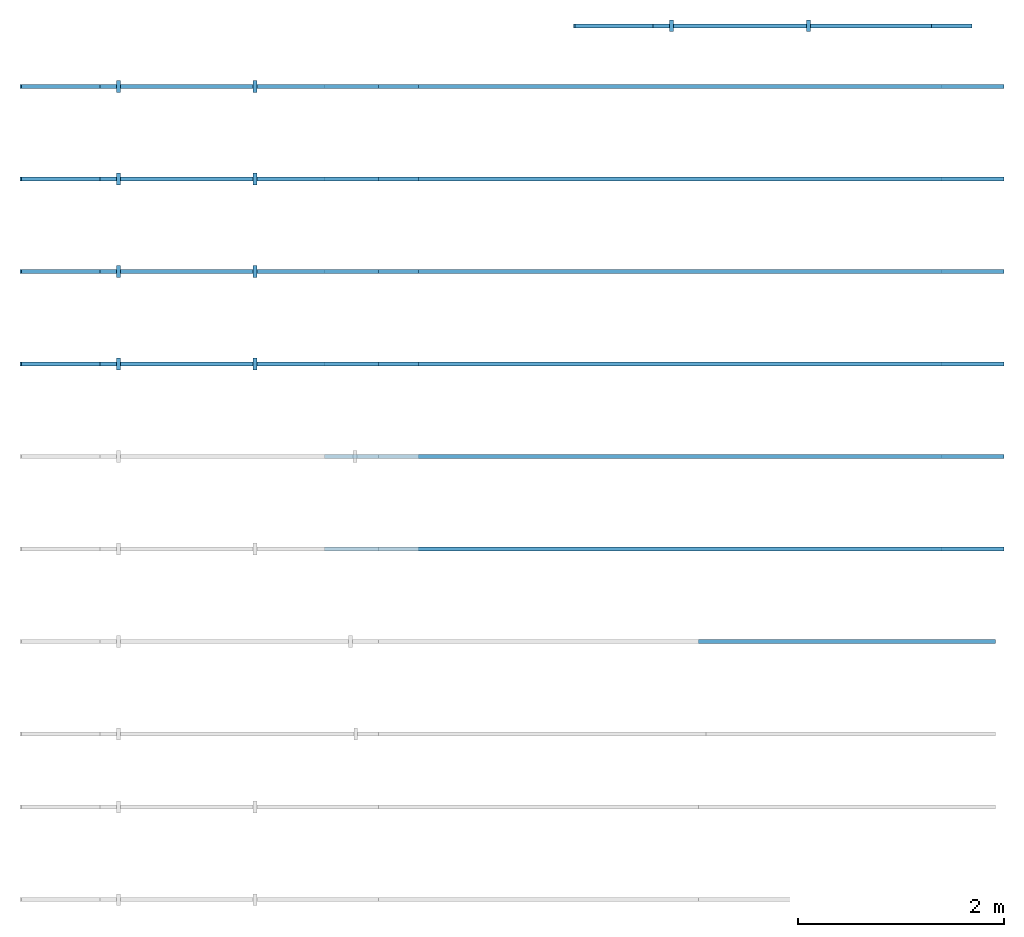
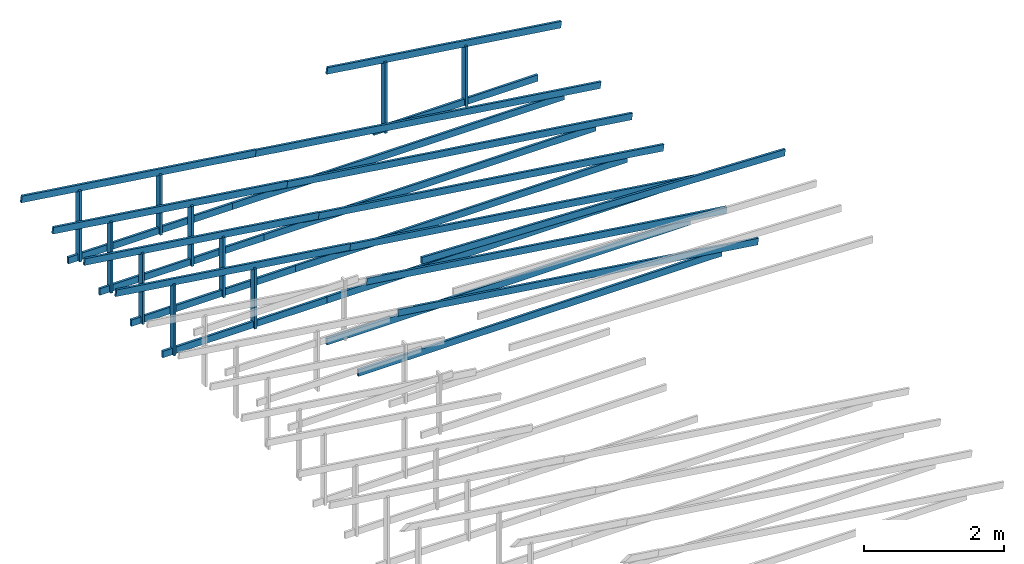
# Not in any storey, part 2 of 2: 33 roofs, 1 element without a shape of its own.
"""IFC4 model written with IfcOpenShell, lengths in millimetres."""

from ifc_helpers import new_model, entity, si_unit, converted_unit, frame, origin_with_axes, origin_2d_with_axis, place, context, subcontext, project, rectangle, extrude, material, material_profile, profile_set, profile_usage, type_object, element, aggregate, save


model = new_model("IFC4")

# Units and contexts
model_context = context("Model", 3, precision=1e-05, world=origin_with_axes())
plan_context = context("Plan", 2, precision=1e-05, world=origin_2d_with_axis())
body_context = subcontext(model_context, "Body", "Model", "MODEL_VIEW")
ifc_project = project(units=[si_unit("VOLUMEUNIT", "CUBIC_METRE"), si_unit("LENGTHUNIT", "METRE", prefix="MILLI"), converted_unit("PLANEANGLEUNIT", "degree", entity("IfcReal", 0.0174532925199433), si_unit("PLANEANGLEUNIT", "RADIAN"), dimensions=[0, 0, 0, 0, 0, 0, 0]), si_unit("AREAUNIT", "SQUARE_METRE")], contexts=[model_context, plan_context])

# Assembly, roofs
assembly_placement = place(None, frame((8638.14163208008, 12731.990814209, 0.0), z_axis=(0.0, 0.0, 1.0), x_axis=(-0.999999999999947, -3.25841369885876e-07, 0.0)))
assembly = element("IfcElementAssembly", 1, at=assembly_placement, Name="Assembly")
ifc_material = material()
ifc_material_profile = material_profile(ifc_material, rectangle(XDim=38.0, YDim=114.0))
ifc_profile_set = profile_set([ifc_material_profile])
ifc_profile_usage_1 = profile_usage(ifc_profile_set, cardinal=5)
roof_type = type_object("IfcRoofType", Name="timber 38x114", PredefinedType="BARREL_ROOF", material=ifc_profile_set)
roof_1_placement = place(assembly_placement, frame((239.999914488218, 439.999502181424, 2478.00016403198), z_axis=(0.99999999999995, -3.13916489247373e-07, -4.37113882867379e-08), x_axis=(3.13916489247373e-07, 0.999999999999951, 0.0)))
roof_1 = element("IfcRoof", 2, at=roof_1_placement, type_object=roof_type, material=ifc_profile_usage_1, Name="Beam", PredefinedType="BARREL_ROOF", context=body_context, shape_type="SweptSolid", body=[
    extrude(rectangle(XDim=38.0, YDim=114.0), origin_with_axes(), (0.0, 0.0, 1.0), 6000.00000000001),
])
ifc_profile_usage_2 = profile_usage(ifc_profile_set, cardinal=5)
roof_2_placement = place(assembly_placement, frame((-359.99951330716, 439.999697686058, 2465.76333045959), z_axis=(0.990268068702914, 1.5806549725193e-07, 0.139173101235031), x_axis=(-1.62920684942918e-07, 0.999999999999986, 2.34930119802329e-08)))
roof_2 = element("IfcRoof", 3, at=roof_2_placement, type_object=roof_type, material=ifc_profile_usage_2, Name="Beam.044", PredefinedType="BARREL_ROOF", context=body_context, shape_type="SweptSolid", body=[
    extrude(rectangle(XDim=38.0, YDim=114.0), origin_with_axes(), (0.0, 0.0, 1.0), 6000.00000000001),
])
ifc_profile_usage_3 = profile_usage(ifc_profile_set, cardinal=5)
roof_3_placement = place(assembly_placement, frame((5334.54051049656, 439.998795843653, 3273.04244041443), z_axis=(0.990268086286663, 1.71346197440185e-07, 0.139172976120085), x_axis=(-1.62920684942918e-07, 0.999999999999984, -7.19328738796233e-08)))
roof_3 = element("IfcRoof", 4, at=roof_3_placement, type_object=roof_type, material=ifc_profile_usage_3, Name="Beam.027", PredefinedType="BARREL_ROOF", context=body_context, shape_type="SweptSolid", body=[
    extrude(rectangle(XDim=38.0, YDim=114.0), origin_with_axes(), (0.0, 0.0, 1.0), 3899.99944705231),
])
ifc_profile_usage_4 = profile_usage(ifc_profile_set, cardinal=5)
roof_4_placement = place(assembly_placement, frame((5719.12875207369, 439.998670528894, 2478.00016403198), z_axis=(0.999999999999973, 1.62920684942916e-07, -1.62920684942925e-07), x_axis=(-1.62920684942918e-07, 0.999999999999987, 7.1609385088314e-15)))
roof_4 = element("IfcRoof", 5, at=roof_4_placement, type_object=roof_type, material=ifc_profile_usage_4, Name="Beam.021", PredefinedType="BARREL_ROOF", context=body_context, shape_type="SweptSolid", body=[
    extrude(rectangle(XDim=38.0, YDim=114.0), origin_with_axes(), (0.0, 0.0, 1.0), 2709.05258213867),
])
ifc_profile_usage_5 = profile_usage(ifc_profile_set, cardinal=5)
roof_5_placement = place(assembly_placement, frame((8248.02651437214, 439.997846509382, 2420.62544822693), z_axis=(1.05540572307067e-14, 1.20724322982826e-07, 0.999999999999993), x_axis=(-0.999999999999996, 8.74227907843234e-08, -2.09332735654617e-22)))
roof_5 = element("IfcRoof", 6, at=roof_5_placement, type_object=roof_type, material=ifc_profile_usage_5, Name="Beam.007", PredefinedType="BARREL_ROOF", context=body_context, shape_type="SweptSolid", body=[
    extrude(rectangle(XDim=38.0, YDim=114.0), origin_with_axes(), (0.0, 0.0, 1.0), 1234.31299754043),
])
ifc_profile_usage_6 = profile_usage(ifc_profile_set, cardinal=5)
roof_6_placement = place(assembly_placement, frame((6916.52026208339, 439.998280369204, 2420.62544822693), z_axis=(1.24156629368653e-14, 1.4201860665253e-07, 0.99999999999999), x_axis=(-0.999999999999996, 8.74227907843234e-08, -7.42746696787314e-22)))
roof_6 = element("IfcRoof", 7, at=roof_6_placement, type_object=roof_type, material=ifc_profile_usage_6, Name="Beam.014", PredefinedType="BARREL_ROOF", context=body_context, shape_type="SweptSolid", body=[
    extrude(rectangle(XDim=38.0, YDim=114.0), origin_with_axes(), (0.0, 0.0, 1.0), 1049.24011663183),
])
ifc_profile_usage_7 = profile_usage(ifc_profile_set, cardinal=5)
roof_7_placement = place(assembly_placement, frame((8248.02680762925, 1339.99746503961, 2420.62544822693), z_axis=(1.05540572307067e-14, 1.20724322982826e-07, 0.999999999999993), x_axis=(-0.999999999999996, 8.74227907843234e-08, -2.09332735654617e-22)))
roof_7 = element("IfcRoof", 8, at=roof_7_placement, type_object=roof_type, material=ifc_profile_usage_7, Name="Beam.019", PredefinedType="BARREL_ROOF", context=body_context, shape_type="SweptSolid", body=[
    extrude(rectangle(XDim=38.0, YDim=114.0), origin_with_axes(), (0.0, 0.0, 1.0), 1234.31299754043),
])
ifc_profile_usage_8 = profile_usage(ifc_profile_set, cardinal=5)
roof_8_placement = place(assembly_placement, frame((5334.54080375367, 1339.99841437388, 3273.04244041443), z_axis=(0.990268086286663, 1.71346197440185e-07, 0.139172976120085), x_axis=(-1.62920684942918e-07, 0.999999999999984, -7.19328738796233e-08)))
roof_8 = element("IfcRoof", 9, at=roof_8_placement, type_object=roof_type, material=ifc_profile_usage_8, Name="Beam.073", PredefinedType="BARREL_ROOF", context=body_context, shape_type="SweptSolid", body=[
    extrude(rectangle(XDim=38.0, YDim=114.0), origin_with_axes(), (0.0, 0.0, 1.0), 3899.99944705231),
])
ifc_profile_usage_9 = profile_usage(ifc_profile_set, cardinal=5)
roof_9_placement = place(assembly_placement, frame((-359.999220049742, 1340.0002698906, 2465.76333045959), z_axis=(0.990268068702914, 1.5806549725193e-07, 0.139173101235031), x_axis=(-1.62920684942918e-07, 0.999999999999986, 2.34930119802329e-08)))
roof_9 = element("IfcRoof", 10, at=roof_9_placement, type_object=roof_type, material=ifc_profile_usage_9, Name="Beam.084", PredefinedType="BARREL_ROOF", context=body_context, shape_type="SweptSolid", body=[
    extrude(rectangle(XDim=38.0, YDim=114.0), origin_with_axes(), (0.0, 0.0, 1.0), 6000.00000000001),
])
ifc_profile_usage_10 = profile_usage(ifc_profile_set, cardinal=5)
roof_10_placement = place(assembly_placement, frame((240.000207745636, 1340.00007438597, 2478.00016403198), z_axis=(0.99999999999995, -3.13916489247373e-07, -4.37113882867379e-08), x_axis=(3.13916489247373e-07, 0.999999999999951, 0.0)))
roof_10 = element("IfcRoof", 11, at=roof_10_placement, type_object=roof_type, material=ifc_profile_usage_10, Name="Beam.034", PredefinedType="BARREL_ROOF", context=body_context, shape_type="SweptSolid", body=[
    extrude(rectangle(XDim=38.0, YDim=114.0), origin_with_axes(), (0.0, 0.0, 1.0), 6000.00000000001),
])
ifc_profile_usage_11 = profile_usage(ifc_profile_set, cardinal=5)
roof_11_placement = place(assembly_placement, frame((5719.1290453308, 1339.99828905912, 2478.00016403198), z_axis=(0.999999999999973, 1.62920684942916e-07, -1.62920684942925e-07), x_axis=(-1.62920684942918e-07, 0.999999999999987, 7.1609385088314e-15)))
roof_11 = element("IfcRoof", 12, at=roof_11_placement, type_object=roof_type, material=ifc_profile_usage_11, Name="Beam.024", PredefinedType="BARREL_ROOF", context=body_context, shape_type="SweptSolid", body=[
    extrude(rectangle(XDim=38.0, YDim=114.0), origin_with_axes(), (0.0, 0.0, 1.0), 2709.05258213867),
])
ifc_profile_usage_12 = profile_usage(ifc_profile_set, cardinal=5)
roof_12_placement = place(assembly_placement, frame((6916.5205553405, 1339.99789889943, 2420.62544822693), z_axis=(1.24156629368653e-14, 1.4201860665253e-07, 0.99999999999999), x_axis=(-0.999999999999996, 8.74227907843234e-08, -7.42746696787314e-22)))
roof_12 = element("IfcRoof", 13, at=roof_12_placement, type_object=roof_type, material=ifc_profile_usage_12, Name="Beam.008", PredefinedType="BARREL_ROOF", context=body_context, shape_type="SweptSolid", body=[
    extrude(rectangle(XDim=38.0, YDim=114.0), origin_with_axes(), (0.0, 0.0, 1.0), 1049.24011663183),
])
ifc_profile_usage_13 = profile_usage(ifc_profile_set, cardinal=5)
roof_13_placement = place(assembly_placement, frame((-359.998926792633, 2239.99988842083, 2465.76333045959), z_axis=(0.990268068702914, 1.5806549725193e-07, 0.139173101235031), x_axis=(-1.62920684942918e-07, 0.999999999999986, 2.34930119802329e-08)))
roof_13 = element("IfcRoof", 14, at=roof_13_placement, type_object=roof_type, material=ifc_profile_usage_13, Name="Beam.042", PredefinedType="BARREL_ROOF", context=body_context, shape_type="SweptSolid", body=[
    extrude(rectangle(XDim=38.0, YDim=114.0), origin_with_axes(), (0.0, 0.0, 1.0), 6000.00000000001),
])
ifc_profile_usage_14 = profile_usage(ifc_profile_set, cardinal=5)
roof_14_placement = place(assembly_placement, frame((240.000501002745, 2239.99969291619, 2478.00016403198), z_axis=(0.99999999999995, -3.13916489247373e-07, -4.37113882867379e-08), x_axis=(3.13916489247373e-07, 0.999999999999951, 0.0)))
roof_14 = element("IfcRoof", 15, at=roof_14_placement, type_object=roof_type, material=ifc_profile_usage_14, Name="Beam.048", PredefinedType="BARREL_ROOF", context=body_context, shape_type="SweptSolid", body=[
    extrude(rectangle(XDim=38.0, YDim=114.0), origin_with_axes(), (0.0, 0.0, 1.0), 6000.00000000001),
])
ifc_profile_usage_15 = profile_usage(ifc_profile_set, cardinal=5)
roof_15_placement = place(assembly_placement, frame((8248.02710088635, 2239.99708356983, 2420.62544822693), z_axis=(1.05540572307067e-14, 1.20724322982826e-07, 0.999999999999993), x_axis=(-0.999999999999996, 8.74227907843234e-08, -2.09332735654617e-22)))
roof_15 = element("IfcRoof", 16, at=roof_15_placement, type_object=roof_type, material=ifc_profile_usage_15, Name="Beam.055", PredefinedType="BARREL_ROOF", context=body_context, shape_type="SweptSolid", body=[
    extrude(rectangle(XDim=38.0, YDim=114.0), origin_with_axes(), (0.0, 0.0, 1.0), 1234.31299754043),
])
ifc_profile_usage_16 = profile_usage(ifc_profile_set, cardinal=5)
roof_16_placement = place(assembly_placement, frame((5334.54109701078, 2239.9980329041, 3273.04244041443), z_axis=(0.990268086286663, 1.71346197440185e-07, 0.139172976120085), x_axis=(-1.62920684942918e-07, 0.999999999999984, -7.19328738796233e-08)))
roof_16 = element("IfcRoof", 17, at=roof_16_placement, type_object=roof_type, material=ifc_profile_usage_16, Name="Beam.080", PredefinedType="BARREL_ROOF", context=body_context, shape_type="SweptSolid", body=[
    extrude(rectangle(XDim=38.0, YDim=114.0), origin_with_axes(), (0.0, 0.0, 1.0), 3899.99944705231),
])
ifc_profile_usage_17 = profile_usage(ifc_profile_set, cardinal=5)
roof_17_placement = place(assembly_placement, frame((5719.1293385879, 2239.99790758934, 2478.00016403198), z_axis=(0.999999999999973, 1.62920684942916e-07, -1.62920684942925e-07), x_axis=(-1.62920684942918e-07, 0.999999999999987, 7.1609385088314e-15)))
roof_17 = element("IfcRoof", 18, at=roof_17_placement, type_object=roof_type, material=ifc_profile_usage_17, Name="Beam.022", PredefinedType="BARREL_ROOF", context=body_context, shape_type="SweptSolid", body=[
    extrude(rectangle(XDim=38.0, YDim=114.0), origin_with_axes(), (0.0, 0.0, 1.0), 2709.05258213867),
])
ifc_profile_usage_18 = profile_usage(ifc_profile_set, cardinal=5)
roof_18_placement = place(assembly_placement, frame((6916.52084859761, 2239.99751742966, 2420.62544822693), z_axis=(1.24156629368653e-14, 1.4201860665253e-07, 0.99999999999999), x_axis=(-0.999999999999996, 8.74227907843234e-08, -7.42746696787314e-22)))
roof_18 = element("IfcRoof", 19, at=roof_18_placement, type_object=roof_type, material=ifc_profile_usage_18, Name="Beam.028", PredefinedType="BARREL_ROOF", context=body_context, shape_type="SweptSolid", body=[
    extrude(rectangle(XDim=38.0, YDim=114.0), origin_with_axes(), (0.0, 0.0, 1.0), 1049.24011663183),
])
ifc_profile_usage_19 = profile_usage(ifc_profile_set, cardinal=5)
roof_19_placement = place(assembly_placement, frame((8248.02691730661, 3139.99765577453, 2420.62544822693), z_axis=(1.05540572307067e-14, 1.20724322982826e-07, 0.999999999999993), x_axis=(-0.999999999999996, 8.74227907843234e-08, -2.09332735654617e-22)))
roof_19 = element("IfcRoof", 20, at=roof_19_placement, type_object=roof_type, material=ifc_profile_usage_19, Name="Beam.006", PredefinedType="BARREL_ROOF", context=body_context, shape_type="SweptSolid", body=[
    extrude(rectangle(XDim=38.0, YDim=114.0), origin_with_axes(), (0.0, 0.0, 1.0), 1234.31299754043),
])
ifc_profile_usage_20 = profile_usage(ifc_profile_set, cardinal=5)
roof_20_placement = place(assembly_placement, frame((240.000794259855, 3139.99931144642, 2478.00016403198), z_axis=(0.99999999999995, -3.13916489247373e-07, -4.37113882867379e-08), x_axis=(3.13916489247373e-07, 0.999999999999951, 0.0)))
roof_20 = element("IfcRoof", 21, at=roof_20_placement, type_object=roof_type, material=ifc_profile_usage_20, Name="Beam.064", PredefinedType="BARREL_ROOF", context=body_context, shape_type="SweptSolid", body=[
    extrude(rectangle(XDim=38.0, YDim=114.0), origin_with_axes(), (0.0, 0.0, 1.0), 6000.00000000001),
])
ifc_profile_usage_21 = profile_usage(ifc_profile_set, cardinal=5)
roof_21_placement = place(assembly_placement, frame((5334.54115184961, 3139.99860510873, 3273.04244041443), z_axis=(0.990268086286663, 1.71346197440185e-07, 0.139172976120085), x_axis=(-1.62920684942918e-07, 0.999999999999984, -7.19328738796233e-08)))
roof_21 = element("IfcRoof", 22, at=roof_21_placement, type_object=roof_type, material=ifc_profile_usage_21, Name="Beam.046", PredefinedType="BARREL_ROOF", context=body_context, shape_type="SweptSolid", body=[
    extrude(rectangle(XDim=38.0, YDim=114.0), origin_with_axes(), (0.0, 0.0, 1.0), 3899.99944705231),
])
ifc_profile_usage_22 = profile_usage(ifc_profile_set, cardinal=5)
roof_22_placement = place(assembly_placement, frame((5719.12939342674, 3139.99847979397, 2478.00016403198), z_axis=(0.999999999999973, 1.62920684942916e-07, -1.62920684942925e-07), x_axis=(-1.62920684942918e-07, 0.999999999999987, 7.1609385088314e-15)))
roof_22 = element("IfcRoof", 23, at=roof_22_placement, type_object=roof_type, material=ifc_profile_usage_22, Name="Beam.052", PredefinedType="BARREL_ROOF", context=body_context, shape_type="SweptSolid", body=[
    extrude(rectangle(XDim=38.0, YDim=114.0), origin_with_axes(), (0.0, 0.0, 1.0), 2709.05258213867),
])
ifc_profile_usage_23 = profile_usage(ifc_profile_set, cardinal=5)
roof_23_placement = place(assembly_placement, frame((-359.998633535524, 3139.99950695105, 2465.76333045959), z_axis=(0.990268068702914, 1.5806549725193e-07, 0.139173101235031), x_axis=(-1.62920684942918e-07, 0.999999999999986, 2.34930119802329e-08)))
roof_23 = element("IfcRoof", 24, at=roof_23_placement, type_object=roof_type, material=ifc_profile_usage_23, Name="Beam.012", PredefinedType="BARREL_ROOF", context=body_context, shape_type="SweptSolid", body=[
    extrude(rectangle(XDim=38.0, YDim=114.0), origin_with_axes(), (0.0, 0.0, 1.0), 6000.00000000001),
])
ifc_profile_usage_24 = profile_usage(ifc_profile_set, cardinal=5)
roof_24_placement = place(assembly_placement, frame((6916.52066501787, 3139.99808963435, 2420.62544822693), z_axis=(1.24156629368653e-14, 1.4201860665253e-07, 0.99999999999999), x_axis=(-0.999999999999996, 8.74227907843234e-08, -7.42746696787314e-22)))
roof_24 = element("IfcRoof", 25, at=roof_24_placement, type_object=roof_type, material=ifc_profile_usage_24, Name="Beam.020", PredefinedType="BARREL_ROOF", context=body_context, shape_type="SweptSolid", body=[
    extrude(rectangle(XDim=38.0, YDim=114.0), origin_with_axes(), (0.0, 0.0, 1.0), 1049.24011663183),
])
ifc_profile_usage_25 = profile_usage(ifc_profile_set, cardinal=5)
roof_25_placement = place(assembly_placement, frame((5711.19784865294, 5839.99781480651, 4800.8017539978), z_axis=(-0.999390828302623, -4.9420837146397e-07, -0.034899459943574), x_axis=(4.88762054828645e-07, -0.999999999999867, 1.6459050300449e-07)))
roof_25 = element("IfcRoof", 26, at=roof_25_placement, type_object=roof_type, material=ifc_profile_usage_25, Name="Beam.025", PredefinedType="BARREL_ROOF", context=body_context, shape_type="SweptSolid", body=[
    extrude(rectangle(XDim=38.0, YDim=114.0), origin_with_axes(), (0.0, 0.0, 1.0), 6000.00000000001),
])
ifc_profile_usage_26 = profile_usage(ifc_profile_set, cardinal=5)
roof_26_placement = place(assembly_placement, frame((-48.1739531368532, -149.514182606163, 3273.04244041443), z_axis=(0.990268086286663, 1.71346197440185e-07, 0.139172976120085), x_axis=(-1.62920684942918e-07, 0.999999999999984, -7.19328738796233e-08)))
roof_26 = element("IfcRoof", 27, at=roof_26_placement, type_object=roof_type, material=ifc_profile_usage_26, Name="Beam.033", PredefinedType="BARREL_ROOF", context=body_context, shape_type="SweptSolid", body=[
    extrude(rectangle(XDim=38.0, YDim=114.0), origin_with_axes(), (0.0, 0.0, 1.0), 3899.99944705231),
])
ifc_profile_usage_27 = profile_usage(ifc_profile_set, cardinal=5)
roof_27_placement = place(assembly_placement, frame((2865.31205073872, -149.515131940433, 2420.62544822693), z_axis=(1.05540572307067e-14, 1.20724322982826e-07, 0.999999999999993), x_axis=(-0.999999999999996, 8.74227907843234e-08, -2.09332735654617e-22)))
roof_27 = element("IfcRoof", 28, at=roof_27_placement, type_object=roof_type, material=ifc_profile_usage_27, Name="Beam.040", PredefinedType="BARREL_ROOF", context=body_context, shape_type="SweptSolid", body=[
    extrude(rectangle(XDim=38.0, YDim=114.0), origin_with_axes(), (0.0, 0.0, 1.0), 1234.31299754043),
])
ifc_profile_usage_28 = profile_usage(ifc_profile_set, cardinal=5)
roof_28_placement = place(assembly_placement, frame((336.414288440274, -149.514307920922, 2478.00016403198), z_axis=(0.999999999999973, 1.62920684942916e-07, -1.62920684942925e-07), x_axis=(-1.62920684942918e-07, 0.999999999999987, 7.1609385088314e-15)))
roof_28 = element("IfcRoof", 29, at=roof_28_placement, type_object=roof_type, material=ifc_profile_usage_28, Name="Beam.067", PredefinedType="BARREL_ROOF", context=body_context, shape_type="SweptSolid", body=[
    extrude(rectangle(XDim=38.0, YDim=114.0), origin_with_axes(), (0.0, 0.0, 1.0), 2709.05258213867),
])
ifc_profile_usage_29 = profile_usage(ifc_profile_set, cardinal=5)
roof_29_placement = place(assembly_placement, frame((1533.80579844998, -149.514698080612, 2420.62544822693), z_axis=(1.24156629368653e-14, 1.4201860665253e-07, 0.99999999999999), x_axis=(-0.999999999999996, 8.74227907843234e-08, -7.42746696787314e-22)))
roof_29 = element("IfcRoof", 30, at=roof_29_placement, type_object=roof_type, material=ifc_profile_usage_29, Name="Beam.076", PredefinedType="BARREL_ROOF", context=body_context, shape_type="SweptSolid", body=[
    extrude(rectangle(XDim=38.0, YDim=114.0), origin_with_axes(), (0.0, 0.0, 1.0), 1049.24011663183),
])
ifc_profile_usage_30 = profile_usage(ifc_profile_set, cardinal=5)
roof_30_placement = place(assembly_placement, frame((240.001087517273, 4039.99988365096, 2478.00016403198), z_axis=(0.99999999999995, -3.13916489247373e-07, -4.37113882867379e-08), x_axis=(3.13916489247373e-07, 0.999999999999951, 0.0)))
roof_30 = element("IfcRoof", 31, at=roof_30_placement, type_object=roof_type, material=ifc_profile_usage_30, Name="Beam.001", PredefinedType="BARREL_ROOF", context=body_context, shape_type="SweptSolid", body=[
    extrude(rectangle(XDim=38.0, YDim=114.0), origin_with_axes(), (0.0, 0.0, 1.0), 6000.00000000001),
])
ifc_profile_usage_31 = profile_usage(ifc_profile_set, cardinal=5)
roof_31_placement = place(assembly_placement, frame((-359.999293952733, 4039.99912548159, 2465.76333045959), z_axis=(0.990268068702914, 1.5806549725193e-07, 0.139173101235031), x_axis=(-1.62920684942918e-07, 0.999999999999986, 2.34930119802329e-08)))
roof_31 = element("IfcRoof", 32, at=roof_31_placement, type_object=roof_type, material=ifc_profile_usage_31, Name="Beam.060", PredefinedType="BARREL_ROOF", context=body_context, shape_type="SweptSolid", body=[
    extrude(rectangle(XDim=38.0, YDim=114.0), origin_with_axes(), (0.0, 0.0, 1.0), 6000.00000000001),
])
ifc_profile_usage_32 = profile_usage(ifc_profile_set, cardinal=5)
roof_32_placement = place(assembly_placement, frame((240.001380774382, 4939.99950218118, 2478.00016403198), z_axis=(0.99999999999995, -3.13916489247373e-07, -4.37113882867379e-08), x_axis=(3.13916489247373e-07, 0.999999999999951, 0.0)))
roof_32 = element("IfcRoof", 33, at=roof_32_placement, type_object=roof_type, material=ifc_profile_usage_32, Name="Beam.031", PredefinedType="BARREL_ROOF", context=body_context, shape_type="SweptSolid", body=[
    extrude(rectangle(XDim=38.0, YDim=114.0), origin_with_axes(), (0.0, 0.0, 1.0), 6000.00000000001),
])
ifc_profile_usage_33 = profile_usage(ifc_profile_set, cardinal=5)
roof_33_placement = place(assembly_placement, frame((-359.999000695312, 4939.99969768613, 2465.76333045959), z_axis=(0.990268068702914, 1.5806549725193e-07, 0.139173101235031), x_axis=(-1.62920684942918e-07, 0.999999999999986, 2.34930119802329e-08)))
roof_33 = element("IfcRoof", 34, at=roof_33_placement, type_object=roof_type, material=ifc_profile_usage_33, Name="Beam.071", PredefinedType="BARREL_ROOF", context=body_context, shape_type="SweptSolid", body=[
    extrude(rectangle(XDim=38.0, YDim=114.0), origin_with_axes(), (0.0, 0.0, 1.0), 6000.00000000001),
])
aggregate(assembly, [roof_1, roof_2, roof_3, roof_4, roof_5, roof_6, roof_7, roof_8, roof_9, roof_10, roof_11, roof_12, roof_13, roof_14, roof_15, roof_16, roof_17, roof_18, roof_19, roof_20, roof_21, roof_22, roof_23, roof_24, roof_25, roof_26, roof_27, roof_28, roof_29, roof_30, roof_31, roof_32, roof_33])

save(model, "model.ifc")
